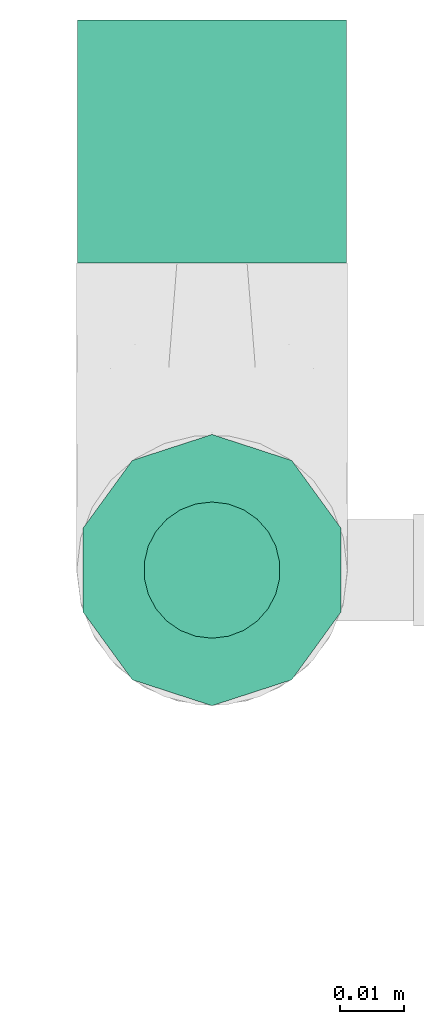
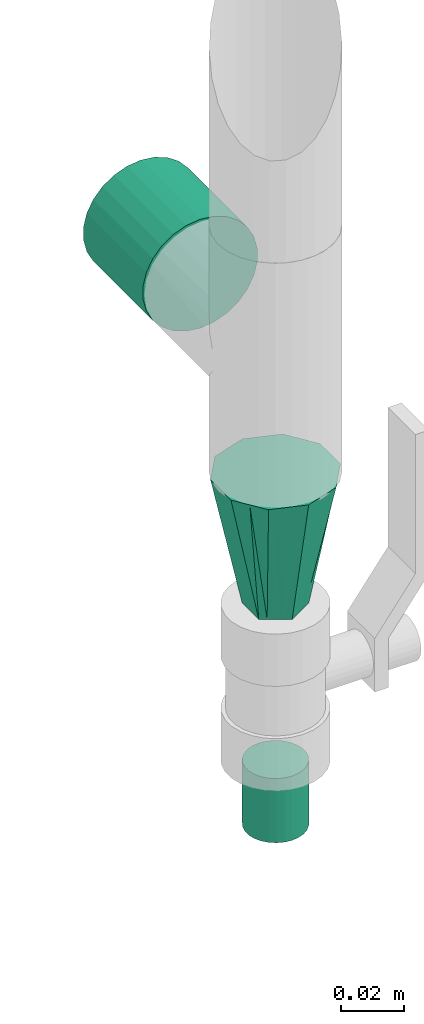
# One storey, part 80 of 93: 3 flow fittings.
"""IFC2X3 building model written with IfcOpenShell, lengths in millimetres."""

from ifc_helpers import new_model, entity, si_unit, converted_unit, derived_unit, direction, frame, origin, origin_2d_with_axis, place, context, subcontext, project, spatial, circle, extrude, faceted_brep, source, transform, mapped, material, type_object, type_shapes, element, save


model = new_model("IFC2X3")

# Units and contexts
model_context = context("Model", 3, precision=0.01, world=origin(), true_north=direction((6.12303176911189e-17, 1.0)))
body_context = subcontext(model_context, "Body", "Model", "MODEL_VIEW")
ifc_project = project(units=[si_unit("LENGTHUNIT", "METRE", prefix="MILLI"), si_unit("AREAUNIT", "SQUARE_METRE"), si_unit("VOLUMEUNIT", "CUBIC_METRE"), converted_unit("PLANEANGLEUNIT", "DEGREE", entity("IfcRatioMeasure", 0.0174532925199433), si_unit("PLANEANGLEUNIT", "RADIAN"), dimensions=[0, 0, 0, 0, 0, 0, 0]), si_unit("MASSUNIT", "GRAM", prefix="KILO"), derived_unit("MASSDENSITYUNIT", [(si_unit("MASSUNIT", "GRAM", prefix="KILO"), 1), (si_unit("LENGTHUNIT", "METRE"), -3)]), derived_unit("MOMENTOFINERTIAUNIT", [(si_unit("LENGTHUNIT", "METRE"), 4)]), si_unit("TIMEUNIT", "SECOND"), si_unit("FREQUENCYUNIT", "HERTZ"), si_unit("THERMODYNAMICTEMPERATUREUNIT", "DEGREE_CELSIUS"), derived_unit("THERMALTRANSMITTANCEUNIT", [(si_unit("MASSUNIT", "GRAM", prefix="KILO"), 1), (si_unit("THERMODYNAMICTEMPERATUREUNIT", "KELVIN"), -1), (si_unit("TIMEUNIT", "SECOND"), -3)]), derived_unit("VOLUMETRICFLOWRATEUNIT", [(si_unit("LENGTHUNIT", "METRE"), 3), (si_unit("TIMEUNIT", "SECOND"), -1)]), derived_unit("MASSFLOWRATEUNIT", [(si_unit("MASSUNIT", "GRAM", prefix="KILO"), 1), (si_unit("TIMEUNIT", "SECOND"), -1)]), derived_unit("ROTATIONALFREQUENCYUNIT", [(si_unit("TIMEUNIT", "SECOND"), -1)]), si_unit("ELECTRICCURRENTUNIT", "AMPERE"), si_unit("ELECTRICVOLTAGEUNIT", "VOLT"), si_unit("POWERUNIT", "WATT"), si_unit("FORCEUNIT", "NEWTON", prefix="KILO"), si_unit("ILLUMINANCEUNIT", "LUX"), si_unit("LUMINOUSFLUXUNIT", "LUMEN"), si_unit("LUMINOUSINTENSITYUNIT", "CANDELA"), derived_unit("USERDEFINED", [(si_unit("MASSUNIT", "GRAM", prefix="KILO"), -1), (si_unit("LENGTHUNIT", "METRE"), -2), (si_unit("TIMEUNIT", "SECOND"), 3), (si_unit("LUMINOUSFLUXUNIT", "LUMEN"), 1)]), derived_unit("LINEARVELOCITYUNIT", [(si_unit("LENGTHUNIT", "METRE"), 1), (si_unit("TIMEUNIT", "SECOND"), -1)]), si_unit("PRESSUREUNIT", "PASCAL"), derived_unit("USERDEFINED", [(si_unit("LENGTHUNIT", "METRE"), -2), (si_unit("MASSUNIT", "GRAM", prefix="KILO"), 1), (si_unit("TIMEUNIT", "SECOND"), -2)]), derived_unit("LINEARFORCEUNIT", [(si_unit("MASSUNIT", "GRAM", prefix="KILO"), 1), (si_unit("LENGTHUNIT", "METRE"), 1), (si_unit("TIMEUNIT", "SECOND"), -2), (si_unit("LENGTHUNIT", "METRE"), -1)]), derived_unit("PLANARFORCEUNIT", [(si_unit("MASSUNIT", "GRAM", prefix="KILO"), 1), (si_unit("LENGTHUNIT", "METRE"), 1), (si_unit("TIMEUNIT", "SECOND"), -2), (si_unit("LENGTHUNIT", "METRE"), -2)])], contexts=[model_context])

# Site, building, storey
site_placement = place(None, origin())
site = spatial("IfcSite", under=ifc_project, at=site_placement, CompositionType="ELEMENT")
building_placement = place(site_placement, origin())
building = spatial("IfcBuilding", under=site, at=building_placement, CompositionType="ELEMENT")
storey_placement = place(building_placement, frame((0.0, 0.0, -4200.0)))
storey = spatial("IfcBuildingStorey", under=building, at=storey_placement, CompositionType="ELEMENT", Elevation=-4200.0)

# Flow fittings
ifc_material = material()
pipe_fitting_type_1 = type_object("IfcPipeFittingType", PredefinedType="NOTDEFINED", material=ifc_material)
shared_shape_1 = source(origin(), body_context, "Body", "SweptSolid", [
    extrude(circle(Radius=10.65, at=origin_2d_with_axis()), frame((0.0, 0.0, 0.0), z_axis=(1.0, 0.0, 0.0), x_axis=(0.0, 1.0, 0.0)), (0.0, 0.0, 1.0), 25.0000000000003),
])
type_shapes(pipe_fitting_type_1, [shared_shape_1])
flow_fitting_1_placement = place(storey_placement, frame((60113.17, 18671.47, 32709.5), z_axis=(1.0, 0.0, 0.0), x_axis=(0.0, 0.0, -1.0)))
element("IfcFlowFitting", 1, at=flow_fitting_1_placement, inside=storey, type_object=pipe_fitting_type_1, material=ifc_material, context=body_context, shape_type="MappedRepresentation", body=[
    mapped(shared_shape_1, transform((0.0, 0.0, 0.0), scale=1.0)),
])
pipe_fitting_type_2 = type_object("IfcPipeFittingType", PredefinedType="NOTDEFINED", material=ifc_material)
shared_shape_2 = source(origin(), body_context, "Body", "SweptSolid", [
    extrude(circle(Radius=21.2, at=origin_2d_with_axis()), frame((0.0, 0.0, 0.0), z_axis=(1.0, 0.0, 0.0), x_axis=(0.0, 1.0, 0.0)), (0.0, 0.0, 1.0), 38.0000000000003),
])
type_shapes(pipe_fitting_type_2, [shared_shape_2])
flow_fitting_2_placement = place(storey_placement, frame((60113.17, 18719.47, 32869.5), z_axis=(1.0, 0.0, 0.0), x_axis=(0.0, 1.0, 0.0)))
element("IfcFlowFitting", 2, at=flow_fitting_2_placement, inside=storey, type_object=pipe_fitting_type_2, material=ifc_material, context=body_context, shape_type="MappedRepresentation", body=[
    mapped(shared_shape_2, transform((0.0, 0.0, 0.0), scale=1.0)),
])
pipe_fitting_type_3 = type_object("IfcPipeFittingType", Name="ADSK_1", PredefinedType="NOTDEFINED", material=ifc_material)
shared_shape_3 = source(origin(), body_context, "Body", "Brep", [
    faceted_brep([(51.0, -21.2, 0.0), (51.0, -19.18, -6.23), (51.0, -17.15, -12.46), (51.0, -11.85, -16.31), (51.0, -6.55, -20.16), (51.0, 0.0, -20.16), (51.0, 6.55, -20.16), (51.0, 11.85, -16.31), (51.0, 17.15, -12.46), (51.0, 18.16, -9.35), (51.0, 19.18, -6.23), (51.0, 21.2, 0.0), (51.0, 19.18, 6.23), (51.0, 17.15, 12.46), (51.0, 11.85, 16.31), (51.0, 6.55, 20.16), (51.0, 0.0, 20.16), (51.0, -6.55, 20.16), (51.0, -11.85, 16.31), (51.0, -17.15, 12.46), (51.0, -18.16, 9.35), (51.0, -19.18, 6.23), (0.0, -9.32, 2.31), (0.0, -7.99, 4.61), (0.0, -6.66, 6.92), (0.0, -5.33, 9.22), (0.0, -2.66, 9.22), (0.0, 0.0, 9.22), (0.0, 2.66, 9.22), (0.0, 5.33, 9.22), (0.0, 6.66, 6.92), (0.0, 7.99, 4.61), (0.0, 9.46, 2.06), (0.0, 10.65, 0.0), (0.0, 9.32, -2.31), (0.0, 7.99, -4.61), (0.0, 6.66, -6.92), (0.0, 5.32, -9.22), (0.0, 2.66, -9.22), (0.0, 0.0, -9.22), (0.0, -2.66, -9.22), (0.0, -5.32, -9.22), (0.0, -6.66, -6.92), (0.0, -7.99, -4.61), (0.0, -9.46, -2.06), (0.0, -10.65, 0.0)], [[[0, 1, 2, 3, 4, 5, 6, 7, 8, 9, 10, 11, 12, 13, 14, 15, 16, 17, 18, 19, 20, 21]], [[22, 23, 24, 25, 26, 27, 28, 29, 30, 31, 32, 33, 34, 35, 36, 37, 38, 39, 40, 41, 42, 43, 44, 45]], [[3, 42, 41]], [[2, 43, 42]], [[1, 0, 44]], [[2, 1, 43]], [[42, 3, 2]], [[4, 41, 40, 39, 38, 37, 6, 5]], [[35, 8, 36]], [[7, 37, 36]], [[11, 34, 33]], [[0, 45, 44]], [[36, 8, 7]], [[34, 11, 10, 9]], [[35, 9, 8]], [[41, 4, 3]], [[43, 1, 44]], [[7, 6, 37]], [[34, 9, 35]], [[14, 30, 29]], [[13, 31, 30]], [[12, 11, 32]], [[13, 12, 31]], [[30, 14, 13]], [[15, 29, 28, 27, 26, 25, 17, 16]], [[23, 19, 24]], [[18, 25, 24]], [[0, 22, 45]], [[11, 33, 32]], [[24, 19, 18]], [[22, 0, 21, 20]], [[23, 20, 19]], [[29, 15, 14]], [[31, 12, 32]], [[18, 17, 25]], [[22, 20, 23]]]),
])
type_shapes(pipe_fitting_type_3, [shared_shape_3])
flow_fitting_3_placement = place(storey_placement, frame((60113.17, 18671.47, 32770.5), z_axis=(1.0, 0.0, 0.0), x_axis=(0.0, 0.0, 1.0)))
element("IfcFlowFitting", 3, at=flow_fitting_3_placement, inside=storey, type_object=pipe_fitting_type_3, material=ifc_material, Name="ADSK_1", ObjectType="ADSK_1", context=body_context, shape_type="MappedRepresentation", body=[
    mapped(shared_shape_3, transform((0.0, 0.0, 0.0), scale=1.0)),
])

save(model, "model.ifc")
